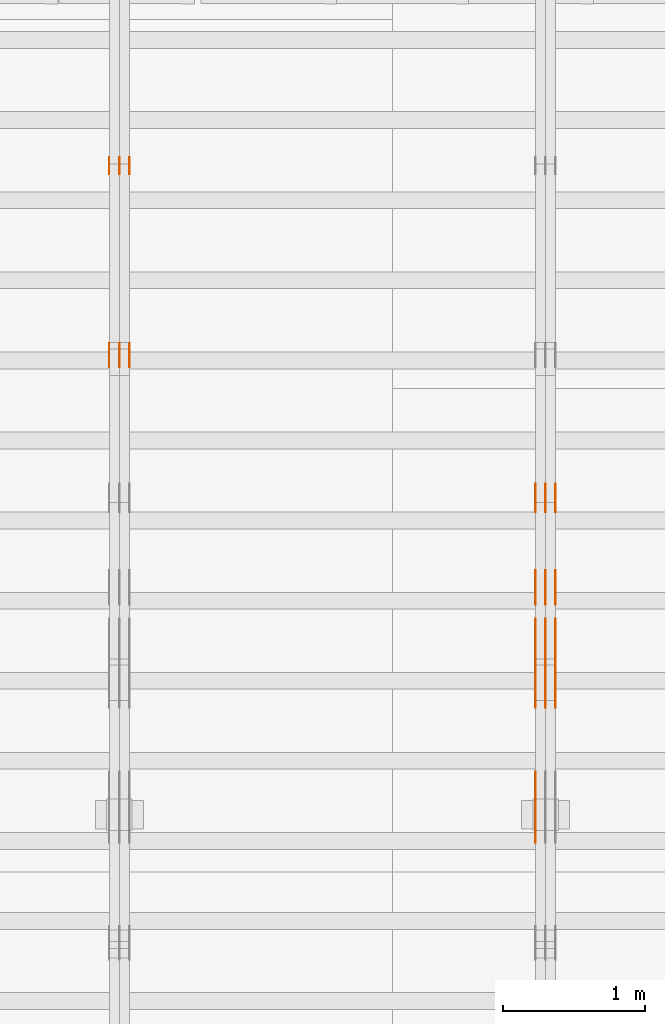
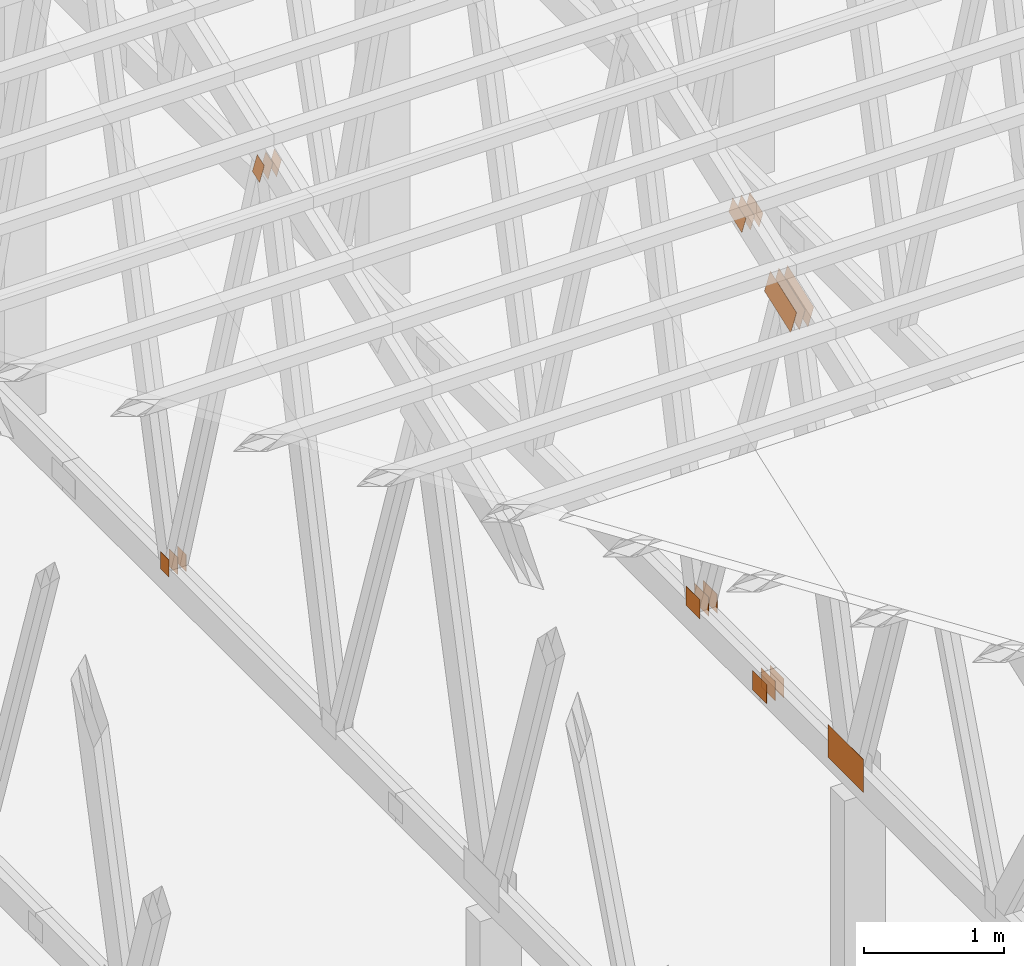
# One storey, part 82 of 189: 25 proxies.
"""IFC2X3 building model written with IfcOpenShell, lengths in millimetres."""

from ifc_helpers import new_model, entity, si_unit, converted_unit, derived_unit, direction, frame, frame_2d, origin, origin_2d_with_axis, place, context, subcontext, project, spatial, polyline, rectangle, outline, extrude, source, transform, mapped, material, type_object, type_shapes, element, save


model = new_model("IFC2X3")

# Units and contexts
model_context = context("Model", 3, precision=0.01, world=origin(), true_north=direction((6.12303176911189e-17, 1.0)))
body_context = subcontext(model_context, "Body", "Model", "MODEL_VIEW")
ifc_project = project(units=[si_unit("LENGTHUNIT", "METRE", prefix="MILLI"), si_unit("AREAUNIT", "SQUARE_METRE"), si_unit("VOLUMEUNIT", "CUBIC_METRE"), converted_unit("PLANEANGLEUNIT", "DEGREE", entity("IfcRatioMeasure", 0.0174532925199433), si_unit("PLANEANGLEUNIT", "RADIAN"), dimensions=[0, 0, 0, 0, 0, 0, 0]), si_unit("MASSUNIT", "GRAM", prefix="KILO"), derived_unit("MASSDENSITYUNIT", [(si_unit("MASSUNIT", "GRAM", prefix="KILO"), 1), (si_unit("LENGTHUNIT", "METRE"), -3)]), si_unit("TIMEUNIT", "SECOND"), si_unit("FREQUENCYUNIT", "HERTZ"), si_unit("THERMODYNAMICTEMPERATUREUNIT", "DEGREE_CELSIUS"), derived_unit("THERMALTRANSMITTANCEUNIT", [(si_unit("MASSUNIT", "GRAM", prefix="KILO"), 1), (si_unit("THERMODYNAMICTEMPERATUREUNIT", "KELVIN"), -1), (si_unit("TIMEUNIT", "SECOND"), -3)]), derived_unit("VOLUMETRICFLOWRATEUNIT", [(si_unit("LENGTHUNIT", "METRE"), 3), (si_unit("TIMEUNIT", "SECOND"), -1)]), si_unit("ELECTRICCURRENTUNIT", "AMPERE"), si_unit("ELECTRICVOLTAGEUNIT", "VOLT"), si_unit("POWERUNIT", "WATT"), si_unit("FORCEUNIT", "NEWTON"), si_unit("ILLUMINANCEUNIT", "LUX"), si_unit("LUMINOUSFLUXUNIT", "LUMEN"), si_unit("LUMINOUSINTENSITYUNIT", "CANDELA"), derived_unit("USERDEFINED", [(si_unit("MASSUNIT", "GRAM", prefix="KILO"), -1), (si_unit("LENGTHUNIT", "METRE"), -2), (si_unit("TIMEUNIT", "SECOND"), 3), (si_unit("LUMINOUSFLUXUNIT", "LUMEN"), 1)]), derived_unit("LINEARVELOCITYUNIT", [(si_unit("LENGTHUNIT", "METRE"), 1), (si_unit("TIMEUNIT", "SECOND"), -1)]), si_unit("PRESSUREUNIT", "PASCAL"), derived_unit("USERDEFINED", [(si_unit("LENGTHUNIT", "METRE"), -2), (si_unit("MASSUNIT", "GRAM", prefix="KILO"), 1), (si_unit("TIMEUNIT", "SECOND"), -2)])], contexts=[model_context])

# Site, building, storey
site_placement = place(None, origin())
site = spatial("IfcSite", under=ifc_project, at=site_placement, CompositionType="ELEMENT")
building_placement = place(site_placement, origin())
building = spatial("IfcBuilding", under=site, at=building_placement, CompositionType="ELEMENT")
storey_placement = place(building_placement, origin())
storey = spatial("IfcBuildingStorey", under=building, at=storey_placement, Name="Default", CompositionType="ELEMENT", Elevation=0.0)

# Proxies
ifc_material_1 = material(Name="IfcSurfaceStyle #76950")
building_element_proxy_type_1 = type_object("IfcBuildingElementProxyType", PredefinedType="NOTDEFINED", material=ifc_material_1)
shared_shape_1 = source(origin(), body_context, "Body", "SweptSolid", [
    extrude(rectangle(XDim=200.0, YDim=168.0, at=origin_2d_with_axis()), frame((100.000765376775, 84.0, 0.0), z_axis=(0.0, 0.0, 1.0), x_axis=(-1.0, 0.0, 0.0)), (0.0, 0.0, 1.0), 1.3),
])
type_shapes(building_element_proxy_type_1, [shared_shape_1])
proxy_1_placement = place(building_placement, frame((12301.3, 10880.1574377482, 365.0), z_axis=(-1.0, 0.0, 0.0), x_axis=(0.0, 1.0, 0.0)))
element("IfcBuildingElementProxy", 1, at=proxy_1_placement, inside=storey, type_object=building_element_proxy_type_1, material=ifc_material_1, context=body_context, shape_type="MappedRepresentation", body=[
    mapped(shared_shape_1, transform((0.0, 0.0, 0.0), scale=1.0)),
])
ifc_material_2 = material(Name="IfcSurfaceStyle #76893")
building_element_proxy_type_2 = type_object("IfcBuildingElementProxyType", PredefinedType="NOTDEFINED", material=ifc_material_2)
shared_shape_2 = source(origin(), body_context, "Body", "SweptSolid", [
    extrude(rectangle(XDim=200.0, YDim=168.0, at=origin_2d_with_axis()), frame((100.000765376775, 84.0, 0.0), z_axis=(0.0, 0.0, 1.0), x_axis=(-1.0, 0.0, 0.0)), (0.0, 0.0, 1.0), 1.29999999999998),
])
type_shapes(building_element_proxy_type_2, [shared_shape_2])
proxy_2_placement = place(building_placement, frame((12230.0, 10880.1574377482, 365.0), z_axis=(-1.0, 0.0, 0.0), x_axis=(0.0, 1.0, 0.0)))
element("IfcBuildingElementProxy", 2, at=proxy_2_placement, inside=storey, type_object=building_element_proxy_type_2, material=ifc_material_2, context=body_context, shape_type="MappedRepresentation", body=[
    mapped(shared_shape_2, transform((0.0, 0.0, 0.0), scale=1.0)),
])
ifc_material_3 = material(Name="IfcSurfaceStyle #76836")
building_element_proxy_type_3 = type_object("IfcBuildingElementProxyType", PredefinedType="NOTDEFINED", material=ifc_material_3)
shared_shape_3 = source(origin(), body_context, "Body", "SweptSolid", [
    extrude(rectangle(XDim=200.0, YDim=168.0, at=origin_2d_with_axis()), frame((100.000765376775, 84.0, 0.0), z_axis=(0.0, 0.0, 1.0), x_axis=(-1.0, 0.0, 0.0)), (0.0, 0.0, 1.0), 1.29999999999998),
])
type_shapes(building_element_proxy_type_3, [shared_shape_3])
proxy_3_placement = place(building_placement, frame((12231.3, 10880.1574377482, 365.0), z_axis=(-1.0, 0.0, 0.0), x_axis=(0.0, 1.0, 0.0)))
element("IfcBuildingElementProxy", 3, at=proxy_3_placement, inside=storey, type_object=building_element_proxy_type_3, material=ifc_material_3, context=body_context, shape_type="MappedRepresentation", body=[
    mapped(shared_shape_3, transform((0.0, 0.0, 0.0), scale=1.0)),
])
ifc_material_4 = material(Name="IfcSurfaceStyle #76779")
building_element_proxy_type_4 = type_object("IfcBuildingElementProxyType", PredefinedType="NOTDEFINED", material=ifc_material_4)
shared_shape_4 = source(origin(), body_context, "Body", "SweptSolid", [
    extrude(rectangle(XDim=200.0, YDim=168.0, at=origin_2d_with_axis()), frame((100.000765376775, 84.0, 0.0), z_axis=(0.0, 0.0, 1.0), x_axis=(-1.0, 0.0, 0.0)), (0.0, 0.0, 1.0), 1.29999999999999),
])
type_shapes(building_element_proxy_type_4, [shared_shape_4])
proxy_4_placement = place(building_placement, frame((12160.0, 10880.1574377482, 365.0), z_axis=(-1.0, 0.0, 0.0), x_axis=(0.0, 1.0, 0.0)))
element("IfcBuildingElementProxy", 4, at=proxy_4_placement, inside=storey, type_object=building_element_proxy_type_4, material=ifc_material_4, context=body_context, shape_type="MappedRepresentation", body=[
    mapped(shared_shape_4, transform((0.0, 0.0, 0.0), scale=1.0)),
])
ifc_material_5 = material(Name="IfcSurfaceStyle #76722")
building_element_proxy_type_5 = type_object("IfcBuildingElementProxyType", PredefinedType="NOTDEFINED", material=ifc_material_5)
shared_shape_5 = source(origin(), body_context, "Body", "SweptSolid", [
    extrude(outline(polyline([(-199.999582244654, -119.99984375717), (200.000344770932, -119.99984375717), (199.999582244655, 119.99984375717), (-200.000344770934, 119.99984375717), (-199.999582244654, -119.99984375717)])), frame((200.000344770932, 120.0000091947, 0.0), z_axis=(0.0, 0.0, 1.0), x_axis=(-1.0, 0.0, 0.0)), (0.0, 0.0, 1.0), 1.29999999999999),
])
type_shapes(building_element_proxy_type_5, [shared_shape_5])
proxy_5_placement = place(building_placement, frame((12301.3, 9961.90704972973, 3612.2451494258), z_axis=(-1.0, 0.0, 0.0), x_axis=(0.0, -0.939692620785908, -0.342020143325669)))
element("IfcBuildingElementProxy", 5, at=proxy_5_placement, inside=storey, type_object=building_element_proxy_type_5, material=ifc_material_5, context=body_context, shape_type="MappedRepresentation", body=[
    mapped(shared_shape_5, transform((0.0, 0.0, 0.0), scale=1.0)),
])
ifc_material_6 = material(Name="IfcSurfaceStyle #76665")
building_element_proxy_type_6 = type_object("IfcBuildingElementProxyType", PredefinedType="NOTDEFINED", material=ifc_material_6)
shared_shape_6 = source(origin(), body_context, "Body", "SweptSolid", [
    extrude(outline(polyline([(-199.999582244654, -119.99984375717), (200.000344770932, -119.99984375717), (199.999582244655, 119.99984375717), (-200.000344770934, 119.99984375717), (-199.999582244654, -119.99984375717)])), frame((200.000344770932, 120.0000091947, 0.0), z_axis=(0.0, 0.0, 1.0), x_axis=(-1.0, 0.0, 0.0)), (0.0, 0.0, 1.0), 1.29999999999997),
])
type_shapes(building_element_proxy_type_6, [shared_shape_6])
proxy_6_placement = place(building_placement, frame((12230.0, 9961.90704972973, 3612.2451494258), z_axis=(-1.0, 0.0, 0.0), x_axis=(0.0, -0.939692620785908, -0.342020143325669)))
element("IfcBuildingElementProxy", 6, at=proxy_6_placement, inside=storey, type_object=building_element_proxy_type_6, material=ifc_material_6, context=body_context, shape_type="MappedRepresentation", body=[
    mapped(shared_shape_6, transform((0.0, 0.0, 0.0), scale=1.0)),
])
ifc_material_7 = material(Name="IfcSurfaceStyle #76608")
building_element_proxy_type_7 = type_object("IfcBuildingElementProxyType", PredefinedType="NOTDEFINED", material=ifc_material_7)
shared_shape_7 = source(origin(), body_context, "Body", "SweptSolid", [
    extrude(outline(polyline([(-199.999582244654, -119.99984375717), (200.000344770932, -119.99984375717), (199.999582244655, 119.99984375717), (-200.000344770934, 119.99984375717), (-199.999582244654, -119.99984375717)])), frame((200.000344770932, 120.0000091947, 0.0), z_axis=(0.0, 0.0, 1.0), x_axis=(-1.0, 0.0, 0.0)), (0.0, 0.0, 1.0), 1.29999999999997),
])
type_shapes(building_element_proxy_type_7, [shared_shape_7])
proxy_7_placement = place(building_placement, frame((12231.3, 9961.90704972973, 3612.2451494258), z_axis=(-1.0, 0.0, 0.0), x_axis=(0.0, -0.939692620785908, -0.342020143325669)))
element("IfcBuildingElementProxy", 7, at=proxy_7_placement, inside=storey, type_object=building_element_proxy_type_7, material=ifc_material_7, context=body_context, shape_type="MappedRepresentation", body=[
    mapped(shared_shape_7, transform((0.0, 0.0, 0.0), scale=1.0)),
])
ifc_material_8 = material(Name="IfcSurfaceStyle #76551")
building_element_proxy_type_8 = type_object("IfcBuildingElementProxyType", PredefinedType="NOTDEFINED", material=ifc_material_8)
shared_shape_8 = source(origin(), body_context, "Body", "SweptSolid", [
    extrude(outline(polyline([(-199.999582244654, -119.99984375717), (200.000344770932, -119.99984375717), (199.999582244655, 119.99984375717), (-200.000344770934, 119.99984375717), (-199.999582244654, -119.99984375717)])), frame((200.000344770932, 120.0000091947, 0.0), z_axis=(0.0, 0.0, 1.0), x_axis=(-1.0, 0.0, 0.0)), (0.0, 0.0, 1.0), 1.29999999999998),
])
type_shapes(building_element_proxy_type_8, [shared_shape_8])
proxy_8_placement = place(building_placement, frame((12160.0, 9961.90704972973, 3612.2451494258), z_axis=(-1.0, 0.0, 0.0), x_axis=(0.0, -0.939692620785908, -0.342020143325669)))
element("IfcBuildingElementProxy", 8, at=proxy_8_placement, inside=storey, type_object=building_element_proxy_type_8, material=ifc_material_8, context=body_context, shape_type="MappedRepresentation", body=[
    mapped(shared_shape_8, transform((0.0, 0.0, 0.0), scale=1.0)),
])
ifc_material_9 = material(Name="IfcSurfaceStyle #75867")
building_element_proxy_type_9 = type_object("IfcBuildingElementProxyType", PredefinedType="NOTDEFINED", material=ifc_material_9)
shared_shape_9 = source(origin(), body_context, "Body", "SweptSolid", [
    extrude(rectangle(XDim=500.0, YDim=288.0, at=frame_2d((0.0, 1.4210854715202e-14), x_axis=(1.0, 0.0))), frame((250.000973740011, 144.0, 0.0), z_axis=(0.0, 0.0, 1.0), x_axis=(-1.0, 0.0, 0.0)), (0.0, 0.0, 1.0), 1.29999999999997),
])
type_shapes(building_element_proxy_type_9, [shared_shape_9])
proxy_9_placement = place(building_placement, frame((12160.0, 8551.90918250999, 389.0), z_axis=(-1.0, 0.0, 0.0), x_axis=(0.0, 1.0, 0.0)))
element("IfcBuildingElementProxy", 9, at=proxy_9_placement, inside=storey, type_object=building_element_proxy_type_9, material=ifc_material_9, context=body_context, shape_type="MappedRepresentation", body=[
    mapped(shared_shape_9, transform((0.0, 0.0, 0.0), scale=1.0)),
])
ifc_material_10 = material(Name="IfcSurfaceStyle #70398")
building_element_proxy_type_10 = type_object("IfcBuildingElementProxyType", PredefinedType="NOTDEFINED", material=ifc_material_10)
shared_shape_10 = source(origin(), body_context, "Body", "SweptSolid", [
    extrude(rectangle(XDim=200.0, YDim=168.0, at=origin_2d_with_axis()), frame((100.0, 84.0, 0.0), z_axis=(0.0, 0.0, 1.0), x_axis=(-1.0, 0.0, 0.0)), (0.0, 0.0, 1.0), 1.3),
])
type_shapes(building_element_proxy_type_10, [shared_shape_10])
proxy_10_placement = place(building_placement, frame((12301.3, 9929.23046875, 206.5), z_axis=(-1.0, 0.0, 0.0), x_axis=(0.0, 1.0, 0.0)))
element("IfcBuildingElementProxy", 10, at=proxy_10_placement, inside=storey, type_object=building_element_proxy_type_10, material=ifc_material_10, context=body_context, shape_type="MappedRepresentation", body=[
    mapped(shared_shape_10, transform((0.0, 0.0, 0.0), scale=1.0)),
])
ifc_material_11 = material(Name="IfcSurfaceStyle #70341")
building_element_proxy_type_11 = type_object("IfcBuildingElementProxyType", PredefinedType="NOTDEFINED", material=ifc_material_11)
shared_shape_11 = source(origin(), body_context, "Body", "SweptSolid", [
    extrude(rectangle(XDim=200.0, YDim=168.0, at=origin_2d_with_axis()), frame((100.0, 84.0, 0.0), z_axis=(0.0, 0.0, 1.0), x_axis=(-1.0, 0.0, 0.0)), (0.0, 0.0, 1.0), 1.29999999999998),
])
type_shapes(building_element_proxy_type_11, [shared_shape_11])
proxy_11_placement = place(building_placement, frame((12230.0, 9929.23046875, 206.5), z_axis=(-1.0, 0.0, 0.0), x_axis=(0.0, 1.0, 0.0)))
element("IfcBuildingElementProxy", 11, at=proxy_11_placement, inside=storey, type_object=building_element_proxy_type_11, material=ifc_material_11, context=body_context, shape_type="MappedRepresentation", body=[
    mapped(shared_shape_11, transform((0.0, 0.0, 0.0), scale=1.0)),
])
ifc_material_12 = material(Name="IfcSurfaceStyle #70284")
building_element_proxy_type_12 = type_object("IfcBuildingElementProxyType", PredefinedType="NOTDEFINED", material=ifc_material_12)
shared_shape_12 = source(origin(), body_context, "Body", "SweptSolid", [
    extrude(rectangle(XDim=200.0, YDim=168.0, at=origin_2d_with_axis()), frame((100.0, 84.0, 0.0), z_axis=(0.0, 0.0, 1.0), x_axis=(-1.0, 0.0, 0.0)), (0.0, 0.0, 1.0), 1.29999999999998),
])
type_shapes(building_element_proxy_type_12, [shared_shape_12])
proxy_12_placement = place(building_placement, frame((12231.3, 9929.23046875, 206.5), z_axis=(-1.0, 0.0, 0.0), x_axis=(0.0, 1.0, 0.0)))
element("IfcBuildingElementProxy", 12, at=proxy_12_placement, inside=storey, type_object=building_element_proxy_type_12, material=ifc_material_12, context=body_context, shape_type="MappedRepresentation", body=[
    mapped(shared_shape_12, transform((0.0, 0.0, 0.0), scale=1.0)),
])
ifc_material_13 = material(Name="IfcSurfaceStyle #70227")
building_element_proxy_type_13 = type_object("IfcBuildingElementProxyType", PredefinedType="NOTDEFINED", material=ifc_material_13)
shared_shape_13 = source(origin(), body_context, "Body", "SweptSolid", [
    extrude(rectangle(XDim=200.0, YDim=168.0, at=origin_2d_with_axis()), frame((100.0, 84.0, 0.0), z_axis=(0.0, 0.0, 1.0), x_axis=(-1.0, 0.0, 0.0)), (0.0, 0.0, 1.0), 1.29999999999999),
])
type_shapes(building_element_proxy_type_13, [shared_shape_13])
proxy_13_placement = place(building_placement, frame((12160.0, 9929.23046875, 206.5), z_axis=(-1.0, 0.0, 0.0), x_axis=(0.0, 1.0, 0.0)))
element("IfcBuildingElementProxy", 13, at=proxy_13_placement, inside=storey, type_object=building_element_proxy_type_13, material=ifc_material_13, context=body_context, shape_type="MappedRepresentation", body=[
    mapped(shared_shape_13, transform((0.0, 0.0, 0.0), scale=1.0)),
])
ifc_material_14 = material(Name="IfcSurfaceStyle #69318")
building_element_proxy_type_14 = type_object("IfcBuildingElementProxyType", PredefinedType="NOTDEFINED", material=ifc_material_14)
shared_shape_14 = source(origin(), body_context, "Body", "SweptSolid", [
    extrude(outline(polyline([(-100.00072430513, -84.0000258989549), (100.000156871239, -84.0000258989549), (99.9997648860508, 84.0000258989549), (-99.9991974521591, 84.0000258989548), (-100.00072430513, -84.0000258989549)])), frame((100.000156871239, 84.0000258989548, 0.0), z_axis=(0.0, 0.0, 1.0), x_axis=(-1.0, 0.0, 0.0)), (0.0, 0.0, 1.0), 1.3),
])
type_shapes(building_element_proxy_type_14, [shared_shape_14])
proxy_14_placement = place(building_placement, frame((12301.3, 10226.4409888304, 4081.14941482552), z_axis=(-1.0, 0.0, 0.0), x_axis=(0.0, 0.939692620785908, 0.342020143325669)))
element("IfcBuildingElementProxy", 14, at=proxy_14_placement, inside=storey, type_object=building_element_proxy_type_14, material=ifc_material_14, context=body_context, shape_type="MappedRepresentation", body=[
    mapped(shared_shape_14, transform((0.0, 0.0, 0.0), scale=1.0)),
])
ifc_material_15 = material(Name="IfcSurfaceStyle #69261")
building_element_proxy_type_15 = type_object("IfcBuildingElementProxyType", PredefinedType="NOTDEFINED", material=ifc_material_15)
shared_shape_15 = source(origin(), body_context, "Body", "SweptSolid", [
    extrude(outline(polyline([(-100.00072430513, -84.0000258989549), (100.000156871239, -84.0000258989549), (99.9997648860508, 84.0000258989549), (-99.9991974521591, 84.0000258989548), (-100.00072430513, -84.0000258989549)])), frame((100.000156871239, 84.0000258989548, 0.0), z_axis=(0.0, 0.0, 1.0), x_axis=(-1.0, 0.0, 0.0)), (0.0, 0.0, 1.0), 1.29999999999998),
])
type_shapes(building_element_proxy_type_15, [shared_shape_15])
proxy_15_placement = place(building_placement, frame((12230.0, 10226.4409888304, 4081.14941482552), z_axis=(-1.0, 0.0, 0.0), x_axis=(0.0, 0.939692620785908, 0.342020143325669)))
element("IfcBuildingElementProxy", 15, at=proxy_15_placement, inside=storey, type_object=building_element_proxy_type_15, material=ifc_material_15, context=body_context, shape_type="MappedRepresentation", body=[
    mapped(shared_shape_15, transform((0.0, 0.0, 0.0), scale=1.0)),
])
ifc_material_16 = material(Name="IfcSurfaceStyle #69204")
building_element_proxy_type_16 = type_object("IfcBuildingElementProxyType", PredefinedType="NOTDEFINED", material=ifc_material_16)
shared_shape_16 = source(origin(), body_context, "Body", "SweptSolid", [
    extrude(outline(polyline([(-100.00072430513, -84.0000258989549), (100.000156871239, -84.0000258989549), (99.9997648860508, 84.0000258989549), (-99.9991974521591, 84.0000258989548), (-100.00072430513, -84.0000258989549)])), frame((100.000156871239, 84.0000258989548, 0.0), z_axis=(0.0, 0.0, 1.0), x_axis=(-1.0, 0.0, 0.0)), (0.0, 0.0, 1.0), 1.29999999999998),
])
type_shapes(building_element_proxy_type_16, [shared_shape_16])
proxy_16_placement = place(building_placement, frame((12231.3, 10226.4409888304, 4081.14941482552), z_axis=(-1.0, 0.0, 0.0), x_axis=(0.0, 0.939692620785908, 0.342020143325669)))
element("IfcBuildingElementProxy", 16, at=proxy_16_placement, inside=storey, type_object=building_element_proxy_type_16, material=ifc_material_16, context=body_context, shape_type="MappedRepresentation", body=[
    mapped(shared_shape_16, transform((0.0, 0.0, 0.0), scale=1.0)),
])
ifc_material_17 = material(Name="IfcSurfaceStyle #69147")
building_element_proxy_type_17 = type_object("IfcBuildingElementProxyType", PredefinedType="NOTDEFINED", material=ifc_material_17)
shared_shape_17 = source(origin(), body_context, "Body", "SweptSolid", [
    extrude(outline(polyline([(-100.00072430513, -84.0000258989549), (100.000156871239, -84.0000258989549), (99.9997648860508, 84.0000258989549), (-99.9991974521591, 84.0000258989548), (-100.00072430513, -84.0000258989549)])), frame((100.000156871239, 84.0000258989548, 0.0), z_axis=(0.0, 0.0, 1.0), x_axis=(-1.0, 0.0, 0.0)), (0.0, 0.0, 1.0), 1.29999999999999),
])
type_shapes(building_element_proxy_type_17, [shared_shape_17])
proxy_17_placement = place(building_placement, frame((12160.0, 10226.4409888304, 4081.14941482552), z_axis=(-1.0, 0.0, 0.0), x_axis=(0.0, 0.939692620785908, 0.342020143325669)))
element("IfcBuildingElementProxy", 17, at=proxy_17_placement, inside=storey, type_object=building_element_proxy_type_17, material=ifc_material_17, context=body_context, shape_type="MappedRepresentation", body=[
    mapped(shared_shape_17, transform((0.0, 0.0, 0.0), scale=1.0)),
])
ifc_material_18 = material(Name="IfcSurfaceStyle #62528")
building_element_proxy_type_18 = type_object("IfcBuildingElementProxyType", PredefinedType="NOTDEFINED", material=ifc_material_18)
shared_shape_18 = source(origin(), body_context, "Body", "SweptSolid", [
    extrude(rectangle(XDim=150.0, YDim=120.0, at=origin_2d_with_axis()), frame((75.0, 60.0000682744794, 0.0), z_axis=(0.0, 0.0, 1.0), x_axis=(-1.0, 0.0, 0.0)), (0.0, 0.0, 1.0), 1.3),
])
type_shapes(building_element_proxy_type_18, [shared_shape_18])
proxy_18_placement = place(building_placement, frame((9301.3, 13259.2753223505, 170.0), z_axis=(-1.0, 0.0, 0.0), x_axis=(0.0, 0.0, 1.0)))
element("IfcBuildingElementProxy", 18, at=proxy_18_placement, inside=storey, type_object=building_element_proxy_type_18, material=ifc_material_18, context=body_context, shape_type="MappedRepresentation", body=[
    mapped(shared_shape_18, transform((0.0, 0.0, 0.0), scale=1.0)),
])
ifc_material_19 = material(Name="IfcSurfaceStyle #62471")
building_element_proxy_type_19 = type_object("IfcBuildingElementProxyType", PredefinedType="NOTDEFINED", material=ifc_material_19)
shared_shape_19 = source(origin(), body_context, "Body", "SweptSolid", [
    extrude(rectangle(XDim=150.0, YDim=120.0, at=origin_2d_with_axis()), frame((75.0, 60.0000682744794, 0.0), z_axis=(0.0, 0.0, 1.0), x_axis=(-1.0, 0.0, 0.0)), (0.0, 0.0, 1.0), 1.29999999999999),
])
type_shapes(building_element_proxy_type_19, [shared_shape_19])
proxy_19_placement = place(building_placement, frame((9230.0, 13259.2753223505, 170.0), z_axis=(-1.0, 0.0, 0.0), x_axis=(0.0, 0.0, 1.0)))
element("IfcBuildingElementProxy", 19, at=proxy_19_placement, inside=storey, type_object=building_element_proxy_type_19, material=ifc_material_19, context=body_context, shape_type="MappedRepresentation", body=[
    mapped(shared_shape_19, transform((0.0, 0.0, 0.0), scale=1.0)),
])
ifc_material_20 = material(Name="IfcSurfaceStyle #62414")
building_element_proxy_type_20 = type_object("IfcBuildingElementProxyType", PredefinedType="NOTDEFINED", material=ifc_material_20)
shared_shape_20 = source(origin(), body_context, "Body", "SweptSolid", [
    extrude(rectangle(XDim=150.0, YDim=120.0, at=origin_2d_with_axis()), frame((75.0, 60.0000682744794, 0.0), z_axis=(0.0, 0.0, 1.0), x_axis=(-1.0, 0.0, 0.0)), (0.0, 0.0, 1.0), 1.29999999999999),
])
type_shapes(building_element_proxy_type_20, [shared_shape_20])
proxy_20_placement = place(building_placement, frame((9231.3, 13259.2753223505, 170.0), z_axis=(-1.0, 0.0, 0.0), x_axis=(0.0, 0.0, 1.0)))
element("IfcBuildingElementProxy", 20, at=proxy_20_placement, inside=storey, type_object=building_element_proxy_type_20, material=ifc_material_20, context=body_context, shape_type="MappedRepresentation", body=[
    mapped(shared_shape_20, transform((0.0, 0.0, 0.0), scale=1.0)),
])
ifc_material_21 = material(Name="IfcSurfaceStyle #62357")
building_element_proxy_type_21 = type_object("IfcBuildingElementProxyType", PredefinedType="NOTDEFINED", material=ifc_material_21)
shared_shape_21 = source(origin(), body_context, "Body", "SweptSolid", [
    extrude(rectangle(XDim=150.0, YDim=120.0, at=origin_2d_with_axis()), frame((75.0, 60.0000682744794, 0.0), z_axis=(0.0, 0.0, 1.0), x_axis=(-1.0, 0.0, 0.0)), (0.0, 0.0, 1.0), 1.29999999999999),
])
type_shapes(building_element_proxy_type_21, [shared_shape_21])
proxy_21_placement = place(building_placement, frame((9160.0, 13259.2753223505, 170.0), z_axis=(-1.0, 0.0, 0.0), x_axis=(0.0, 0.0, 1.0)))
element("IfcBuildingElementProxy", 21, at=proxy_21_placement, inside=storey, type_object=building_element_proxy_type_21, material=ifc_material_21, context=body_context, shape_type="MappedRepresentation", body=[
    mapped(shared_shape_21, transform((0.0, 0.0, 0.0), scale=1.0)),
])
ifc_material_22 = material(Name="IfcSurfaceStyle #61844")
building_element_proxy_type_22 = type_object("IfcBuildingElementProxyType", PredefinedType="NOTDEFINED", material=ifc_material_22)
shared_shape_22 = source(origin(), body_context, "Body", "SweptSolid", [
    extrude(outline(polyline([(-54.000518665753, -99.9999712116328), (54.0009733694842, -99.9999712116328), (53.9996516525364, 99.999866626518), (-54.0001063562676, 100.000075796748), (-54.000518665753, -99.9999712116328)])), frame((100.000049683045, 54.0003125110034, 0.0), z_axis=(0.0, 0.0, 1.0), x_axis=(-2.06154694206879e-06, 1.0, 0.0)), (0.0, 0.0, 1.0), 1.3),
])
type_shapes(building_element_proxy_type_22, [shared_shape_22])
proxy_22_placement = place(building_placement, frame((9301.3, 12002.0392854883, 4614.07927340247), z_axis=(-1.0, 0.0, 0.0), x_axis=(0.0, 0.342020143325669, -0.939692620785908)))
element("IfcBuildingElementProxy", 22, at=proxy_22_placement, inside=storey, type_object=building_element_proxy_type_22, material=ifc_material_22, context=body_context, shape_type="MappedRepresentation", body=[
    mapped(shared_shape_22, transform((0.0, 0.0, 0.0), scale=1.0)),
])
ifc_material_23 = material(Name="IfcSurfaceStyle #61787")
building_element_proxy_type_23 = type_object("IfcBuildingElementProxyType", PredefinedType="NOTDEFINED", material=ifc_material_23)
shared_shape_23 = source(origin(), body_context, "Body", "SweptSolid", [
    extrude(outline(polyline([(-54.000518665753, -99.9999712116328), (54.0009733694842, -99.9999712116328), (53.9996516525364, 99.999866626518), (-54.0001063562676, 100.000075796748), (-54.000518665753, -99.9999712116328)])), frame((100.000049683045, 54.0003125110034, 0.0), z_axis=(0.0, 0.0, 1.0), x_axis=(-2.06154694206879e-06, 1.0, 0.0)), (0.0, 0.0, 1.0), 1.29999999999998),
])
type_shapes(building_element_proxy_type_23, [shared_shape_23])
proxy_23_placement = place(building_placement, frame((9230.0, 12002.0392854883, 4614.07927340247), z_axis=(-1.0, 0.0, 0.0), x_axis=(0.0, 0.342020143325669, -0.939692620785908)))
element("IfcBuildingElementProxy", 23, at=proxy_23_placement, inside=storey, type_object=building_element_proxy_type_23, material=ifc_material_23, context=body_context, shape_type="MappedRepresentation", body=[
    mapped(shared_shape_23, transform((0.0, 0.0, 0.0), scale=1.0)),
])
ifc_material_24 = material(Name="IfcSurfaceStyle #61730")
building_element_proxy_type_24 = type_object("IfcBuildingElementProxyType", PredefinedType="NOTDEFINED", material=ifc_material_24)
shared_shape_24 = source(origin(), body_context, "Body", "SweptSolid", [
    extrude(outline(polyline([(-54.000518665753, -99.9999712116328), (54.0009733694842, -99.9999712116328), (53.9996516525364, 99.999866626518), (-54.0001063562676, 100.000075796748), (-54.000518665753, -99.9999712116328)])), frame((100.000049683045, 54.0003125110034, 0.0), z_axis=(0.0, 0.0, 1.0), x_axis=(-2.06154694206879e-06, 1.0, 0.0)), (0.0, 0.0, 1.0), 1.29999999999998),
])
type_shapes(building_element_proxy_type_24, [shared_shape_24])
proxy_24_placement = place(building_placement, frame((9231.3, 12002.0392854883, 4614.07927340247), z_axis=(-1.0, 0.0, 0.0), x_axis=(0.0, 0.342020143325669, -0.939692620785908)))
element("IfcBuildingElementProxy", 24, at=proxy_24_placement, inside=storey, type_object=building_element_proxy_type_24, material=ifc_material_24, context=body_context, shape_type="MappedRepresentation", body=[
    mapped(shared_shape_24, transform((0.0, 0.0, 0.0), scale=1.0)),
])
ifc_material_25 = material(Name="IfcSurfaceStyle #61673")
building_element_proxy_type_25 = type_object("IfcBuildingElementProxyType", PredefinedType="NOTDEFINED", material=ifc_material_25)
shared_shape_25 = source(origin(), body_context, "Body", "SweptSolid", [
    extrude(outline(polyline([(-54.000518665753, -99.9999712116328), (54.0009733694842, -99.9999712116328), (53.9996516525364, 99.999866626518), (-54.0001063562676, 100.000075796748), (-54.000518665753, -99.9999712116328)])), frame((100.000049683045, 54.0003125110034, 0.0), z_axis=(0.0, 0.0, 1.0), x_axis=(-2.06154694206879e-06, 1.0, 0.0)), (0.0, 0.0, 1.0), 1.29999999999999),
])
type_shapes(building_element_proxy_type_25, [shared_shape_25])
proxy_25_placement = place(building_placement, frame((9160.0, 12002.0392854883, 4614.07927340247), z_axis=(-1.0, 0.0, 0.0), x_axis=(0.0, 0.342020143325669, -0.939692620785908)))
element("IfcBuildingElementProxy", 25, at=proxy_25_placement, inside=storey, type_object=building_element_proxy_type_25, material=ifc_material_25, context=body_context, shape_type="MappedRepresentation", body=[
    mapped(shared_shape_25, transform((0.0, 0.0, 0.0), scale=1.0)),
])

save(model, "model.ifc")
